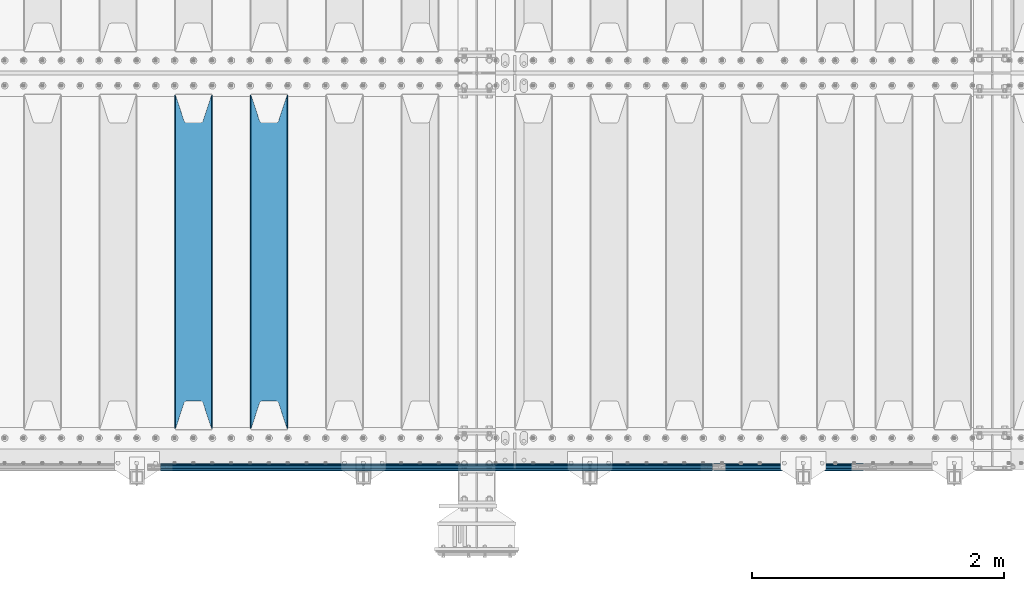
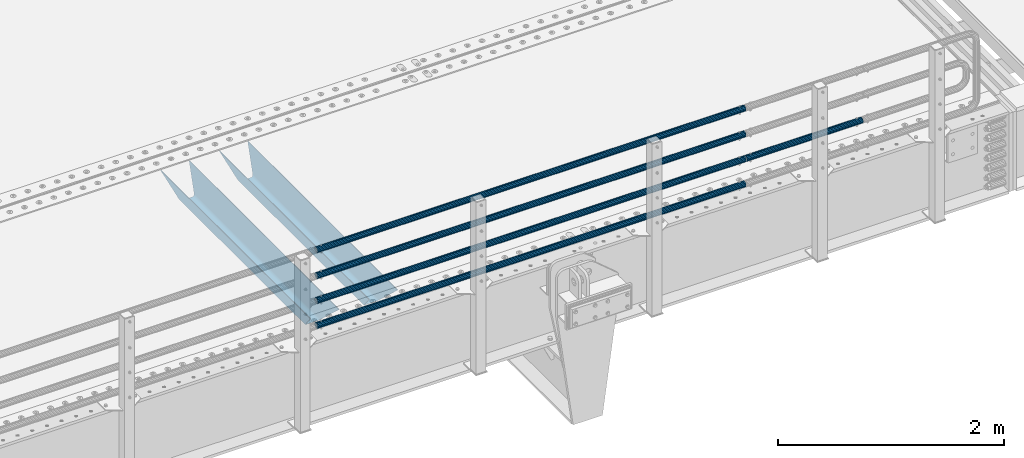
# One storey, part 108 of 257: 7 beams.
"""IFC2X3 building model written with IfcOpenShell, lengths in millimetres."""

from ifc_helpers import new_model, si_unit, frame, origin_with_axes, place, context, subcontext, project, spatial, faceted_brep, material, type_object, element, save


model = new_model("IFC2X3")

# Units and contexts
model_context = context("Model", 3, precision=1e-05, world=origin_with_axes())
body_context = subcontext(model_context, "Body", "Model", "MODEL_VIEW")
ifc_project = project(units=[si_unit("LENGTHUNIT", "METRE", prefix="MILLI"), si_unit("AREAUNIT", "SQUARE_METRE"), si_unit("VOLUMEUNIT", "CUBIC_METRE"), si_unit("MASSUNIT", "GRAM", prefix="KILO"), si_unit("TIMEUNIT", "SECOND"), si_unit("PLANEANGLEUNIT", "RADIAN"), si_unit("SOLIDANGLEUNIT", "STERADIAN"), si_unit("THERMODYNAMICTEMPERATUREUNIT", "DEGREE_CELSIUS"), si_unit("LUMINOUSINTENSITYUNIT", "LUMEN")], contexts=[model_context])

# Site, building, storey
site_placement = place(None, origin_with_axes())
site = spatial("IfcSite", under=ifc_project, at=site_placement, CompositionType="ELEMENT")
building_placement = place(site_placement, origin_with_axes())
building = spatial("IfcBuilding", under=site, at=building_placement, Name="Standard", CompositionType="ELEMENT")
storey_placement = place(building_placement, origin_with_axes())
storey = spatial("IfcBuildingStorey", under=building, at=storey_placement, Name="Undefined", CompositionType="ELEMENT", Elevation=0.0)

# Beams
ifc_material_1 = material(Name="STEEL/S355N")
beam_type_1 = type_object("IfcBeamType", PredefinedType="NOTDEFINED")
beam_1_placement = place(storey_placement, frame((53050.0, 175.0, -115.0), z_axis=(0.0, 0.0, 1.0), x_axis=(0.0, 1.0, 0.0)))
element("IfcBeam", 1, at=beam_1_placement, inside=storey, type_object=beam_type_1, material=ifc_material_1, context=body_context, shape_type="Brep", body=[
    faceted_brep([(0.0, 150.0, 115.0), (0.0, 143.690000000002, 115.0), (2650.00000000297, 143.690000000002, 115.0), (2650.00000000297, 150.0, 115.0), (2650.00000000297, 142.059565218406, 110.0000000031), (2650.00000000297, 148.369565218403, 110.0000000031), (2441.90079219208, -80.1103600731149, -98.0992078077845), (2437.7588105432, -77.5672621345584, -102.241189456673), (2434.06523489746, -74.4080125315522, -105.934765102404), (2430.91086095089, -70.7102721255724, -109.089139048974), (2428.37322971128, -66.5649389910031, -111.626770288588), (2426.51472138055, -62.0739139532889, -113.485278619323), (2425.38102192091, -57.3475956567636, -114.618978078955), (2424.99999999987, -52.5021667386536, -115.0), (2424.99999999987, 52.5021667386536, -115.0), (2425.38102192091, 57.3475956567636, -114.618978078955), (2426.51472138055, 62.0739139532889, -113.485278619323), (2428.37322971128, 66.5649389910031, -111.626770288588), (2430.91086095089, 70.7102721255724, -109.089139048974), (2434.06523489746, 74.4080125315522, -105.934765102404), (2437.7588105432, 77.5672621345584, -102.241189456673), (2441.90079219208, 80.1103600731149, -98.0992078077846), (2446.38936140511, 81.9747917625791, -93.6106385947584), (2448.24948500409, 76.2713538057287, -91.7505149957729), (2444.62967112262, 74.76777986261, -95.3703288772456), (2441.28936334126, 72.7168944282894, -98.710636658607), (2438.31067330438, 70.1691124903809, -101.689326695487), (2435.76682334747, 67.1870637758839, -104.233176652398), (2433.72034654133, 63.8440531834931, -106.279653458539), (2432.22154950041, 60.2222587982324, -107.778450499454), (2431.30727574265, 56.4107117849126, -108.692724257221), (2430.99999999987, 52.5031078186876, -109.0), (2430.99999999987, -52.5031078186876, -109.0), (2431.30727574265, -56.4107117849126, -108.692724257221), (2432.22154950041, -60.2222587982324, -107.778450499454), (2433.72034654133, -63.8440531834931, -106.279653458539), (2435.76682334747, -67.1870637758839, -104.233176652398), (2438.31067330438, -70.1691124903809, -101.689326695487), (2441.28936334126, -72.7168944282894, -98.7106366586071), (2444.62967112262, -74.76777986261, -95.3703288772457), (2448.24948500409, -76.2713538057287, -91.7505149957729), (2650.00000000297, -142.059565218406, 110.0000000031), (2650.00000000297, -148.369565218403, 110.0000000031), (2446.38936140511, -81.9747917625791, -93.6106385947584), (2650.00000000297, -143.690000000002, 115.0), (2650.00000000297, -150.0, 115.0), (0.0, -143.690000000002, 115.0), (0.0, -150.0, 115.0), (0.0, -148.369565218258, 110.000000002662), (203.61063859742, -81.9747917625791, -93.6106385947584), (208.099207810447, -80.1103600731149, -98.0992078077845), (212.241189459335, -77.5672621345584, -102.241189456673), (215.934765105066, -74.4080125315522, -105.934765102404), (219.089139051636, -70.7102721255724, -109.089139048974), (221.626770291251, -66.5649389910031, -111.626770288588), (223.485278621985, -62.0739139532889, -113.485278619323), (224.618978081617, -57.3475956567636, -114.618978078955), (225.000000002662, -52.5021667386536, -115.0), (225.000000002662, 52.5021667386536, -115.0), (224.618978081617, 57.3475956567636, -114.618978078955), (223.485278621985, 62.0739139532889, -113.485278619323), (221.626770291251, 66.5649389910031, -111.626770288588), (219.089139051636, 70.7102721255724, -109.089139048974), (215.934765105066, 74.4080125315522, -105.934765102404), (212.241189459335, 77.5672621345584, -102.241189456673), (208.099207810447, 80.1103600731149, -98.0992078077846), (203.61063859742, 81.9747917625791, -93.6106385947584), (0.0, 148.369565218258, 110.000000002662), (0.0, 142.05956521826, 110.000000002662), (201.750514998435, 76.2713538057287, -91.7505149957729), (205.370328879908, 74.76777986261, -95.3703288772456), (208.710636661269, 72.7168944282894, -98.710636658607), (211.689326698149, 70.1691124903809, -101.689326695487), (214.233176655061, 67.1870637758839, -104.233176652398), (216.279653461201, 63.8440531834931, -106.279653458539), (217.778450502116, 60.2222587982324, -107.778450499454), (218.692724259884, 56.4107117849126, -108.692724257221), (219.000000002662, 52.5031078186876, -109.0), (219.000000002662, -52.5031078186876, -109.0), (218.692724259884, -56.4107117849126, -108.692724257221), (217.778450502116, -60.2222587982324, -107.778450499454), (216.279653461201, -63.8440531834931, -106.279653458539), (214.233176655061, -67.1870637758839, -104.233176652398), (211.689326698149, -70.1691124903809, -101.689326695487), (208.710636661269, -72.7168944282894, -98.7106366586071), (205.370328879908, -74.76777986261, -95.3703288772457), (201.750514998435, -76.2713538057287, -91.7505149957729), (0.0, -142.05956521826, 110.000000002662)], [[[0, 1, 2, 3]], [[3, 2, 4, 5]], [[6, 7, 8, 9, 10, 11, 12, 13, 14, 15, 16, 17, 18, 19, 20, 21, 22, 5, 4, 23, 24, 25, 26, 27, 28, 29, 30, 31, 32, 33, 34, 35, 36, 37, 38, 39, 40, 41, 42, 43]], [[44, 45, 42, 41]], [[46, 47, 45, 44]], [[43, 42, 45, 47, 48, 49]], [[6, 43, 49, 50]], [[7, 6, 50, 51]], [[8, 7, 51, 52]], [[9, 8, 52, 53]], [[10, 9, 53, 54]], [[11, 10, 54, 55]], [[12, 11, 55, 56]], [[13, 12, 56, 57]], [[14, 13, 57, 58]], [[15, 14, 58, 59]], [[16, 15, 59, 60]], [[17, 16, 60, 61]], [[18, 17, 61, 62]], [[19, 18, 62, 63]], [[20, 19, 63, 64]], [[21, 20, 64, 65]], [[22, 21, 65, 66]], [[0, 3, 5, 22, 66, 67]], [[1, 0, 67, 68]], [[23, 4, 2, 1, 68, 69]], [[24, 23, 69, 70]], [[25, 24, 70, 71]], [[26, 25, 71, 72]], [[27, 26, 72, 73]], [[28, 27, 73, 74]], [[29, 28, 74, 75]], [[30, 29, 75, 76]], [[31, 30, 76, 77]], [[32, 31, 77, 78]], [[33, 32, 78, 79]], [[34, 33, 79, 80]], [[35, 34, 80, 81]], [[36, 35, 81, 82]], [[37, 36, 82, 83]], [[38, 37, 83, 84]], [[39, 38, 84, 85]], [[40, 39, 85, 86]], [[46, 44, 41, 40, 86, 87]], [[47, 46, 87, 48]], [[86, 85, 84, 83, 82, 81, 80, 79, 78, 77, 76, 75, 74, 73, 72, 71, 70, 69, 68, 67, 66, 65, 64, 63, 62, 61, 60, 59, 58, 57, 56, 55, 54, 53, 52, 51, 50, 49, 48, 87]]]),
])
beam_2_placement = place(storey_placement, frame((52450.0, 175.0, -115.0), z_axis=(0.0, 0.0, 1.0), x_axis=(0.0, 1.0, 0.0)))
element("IfcBeam", 2, at=beam_2_placement, inside=storey, type_object=beam_type_1, material=ifc_material_1, context=body_context, shape_type="Brep", body=[
    faceted_brep([(0.0, 150.0, 115.0), (0.0, 143.690000000002, 115.0), (2650.00000000297, 143.690000000002, 115.0), (2650.00000000297, 150.0, 115.0), (2650.00000000297, 142.059565218406, 110.0000000031), (2650.00000000297, 148.369565218403, 110.0000000031), (2441.90079219208, -80.1103600731149, -98.0992078077845), (2437.7588105432, -77.5672621345584, -102.241189456673), (2434.06523489746, -74.4080125315522, -105.934765102404), (2430.91086095089, -70.7102721255724, -109.089139048974), (2428.37322971128, -66.5649389910031, -111.626770288588), (2426.51472138055, -62.0739139532889, -113.485278619323), (2425.38102192091, -57.3475956567636, -114.618978078955), (2424.99999999987, -52.5021667386536, -115.0), (2424.99999999987, 52.5021667386536, -115.0), (2425.38102192091, 57.3475956567636, -114.618978078955), (2426.51472138055, 62.0739139532889, -113.485278619323), (2428.37322971128, 66.5649389910031, -111.626770288588), (2430.91086095089, 70.7102721255724, -109.089139048974), (2434.06523489746, 74.4080125315522, -105.934765102404), (2437.7588105432, 77.5672621345584, -102.241189456673), (2441.90079219208, 80.1103600731149, -98.0992078077846), (2446.38936140511, 81.9747917625791, -93.6106385947584), (2448.24948500409, 76.2713538057287, -91.7505149957729), (2444.62967112262, 74.76777986261, -95.3703288772456), (2441.28936334126, 72.7168944282894, -98.710636658607), (2438.31067330438, 70.1691124903809, -101.689326695487), (2435.76682334747, 67.1870637758839, -104.233176652398), (2433.72034654133, 63.8440531834931, -106.279653458539), (2432.22154950041, 60.2222587982324, -107.778450499454), (2431.30727574265, 56.4107117849126, -108.692724257221), (2430.99999999987, 52.5031078186876, -109.0), (2430.99999999987, -52.5031078186876, -109.0), (2431.30727574265, -56.4107117849126, -108.692724257221), (2432.22154950041, -60.2222587982324, -107.778450499454), (2433.72034654133, -63.8440531834931, -106.279653458539), (2435.76682334747, -67.1870637758839, -104.233176652398), (2438.31067330438, -70.1691124903809, -101.689326695487), (2441.28936334126, -72.7168944282894, -98.7106366586071), (2444.62967112262, -74.76777986261, -95.3703288772457), (2448.24948500409, -76.2713538057287, -91.7505149957729), (2650.00000000297, -142.059565218406, 110.0000000031), (2650.00000000297, -148.369565218403, 110.0000000031), (2446.38936140511, -81.9747917625791, -93.6106385947584), (2650.00000000297, -143.690000000002, 115.0), (2650.00000000297, -150.0, 115.0), (0.0, -143.690000000002, 115.0), (0.0, -150.0, 115.0), (0.0, -148.369565218258, 110.000000002662), (203.61063859742, -81.9747917625791, -93.6106385947584), (208.099207810447, -80.1103600731149, -98.0992078077845), (212.241189459335, -77.5672621345584, -102.241189456673), (215.934765105066, -74.4080125315522, -105.934765102404), (219.089139051636, -70.7102721255724, -109.089139048974), (221.626770291251, -66.5649389910031, -111.626770288588), (223.485278621985, -62.0739139532889, -113.485278619323), (224.618978081617, -57.3475956567636, -114.618978078955), (225.000000002662, -52.5021667386536, -115.0), (225.000000002662, 52.5021667386536, -115.0), (224.618978081617, 57.3475956567636, -114.618978078955), (223.485278621985, 62.0739139532889, -113.485278619323), (221.626770291251, 66.5649389910031, -111.626770288588), (219.089139051636, 70.7102721255724, -109.089139048974), (215.934765105066, 74.4080125315522, -105.934765102404), (212.241189459335, 77.5672621345584, -102.241189456673), (208.099207810447, 80.1103600731149, -98.0992078077846), (203.61063859742, 81.9747917625791, -93.6106385947584), (0.0, 148.369565218258, 110.000000002662), (0.0, 142.05956521826, 110.000000002662), (201.750514998435, 76.2713538057287, -91.7505149957729), (205.370328879908, 74.76777986261, -95.3703288772456), (208.710636661269, 72.7168944282894, -98.710636658607), (211.689326698149, 70.1691124903809, -101.689326695487), (214.233176655061, 67.1870637758839, -104.233176652398), (216.279653461201, 63.8440531834931, -106.279653458539), (217.778450502116, 60.2222587982324, -107.778450499454), (218.692724259884, 56.4107117849126, -108.692724257221), (219.000000002662, 52.5031078186876, -109.0), (219.000000002662, -52.5031078186876, -109.0), (218.692724259884, -56.4107117849126, -108.692724257221), (217.778450502116, -60.2222587982324, -107.778450499454), (216.279653461201, -63.8440531834931, -106.279653458539), (214.233176655061, -67.1870637758839, -104.233176652398), (211.689326698149, -70.1691124903809, -101.689326695487), (208.710636661269, -72.7168944282894, -98.7106366586071), (205.370328879908, -74.76777986261, -95.3703288772457), (201.750514998435, -76.2713538057287, -91.7505149957729), (0.0, -142.05956521826, 110.000000002662)], [[[0, 1, 2, 3]], [[3, 2, 4, 5]], [[6, 7, 8, 9, 10, 11, 12, 13, 14, 15, 16, 17, 18, 19, 20, 21, 22, 5, 4, 23, 24, 25, 26, 27, 28, 29, 30, 31, 32, 33, 34, 35, 36, 37, 38, 39, 40, 41, 42, 43]], [[44, 45, 42, 41]], [[46, 47, 45, 44]], [[43, 42, 45, 47, 48, 49]], [[6, 43, 49, 50]], [[7, 6, 50, 51]], [[8, 7, 51, 52]], [[9, 8, 52, 53]], [[10, 9, 53, 54]], [[11, 10, 54, 55]], [[12, 11, 55, 56]], [[13, 12, 56, 57]], [[14, 13, 57, 58]], [[15, 14, 58, 59]], [[16, 15, 59, 60]], [[17, 16, 60, 61]], [[18, 17, 61, 62]], [[19, 18, 62, 63]], [[20, 19, 63, 64]], [[21, 20, 64, 65]], [[22, 21, 65, 66]], [[0, 3, 5, 22, 66, 67]], [[1, 0, 67, 68]], [[23, 4, 2, 1, 68, 69]], [[24, 23, 69, 70]], [[25, 24, 70, 71]], [[26, 25, 71, 72]], [[27, 26, 72, 73]], [[28, 27, 73, 74]], [[29, 28, 74, 75]], [[30, 29, 75, 76]], [[31, 30, 76, 77]], [[32, 31, 77, 78]], [[33, 32, 78, 79]], [[34, 33, 79, 80]], [[35, 34, 80, 81]], [[36, 35, 81, 82]], [[37, 36, 82, 83]], [[38, 37, 83, 84]], [[39, 38, 84, 85]], [[40, 39, 85, 86]], [[46, 44, 41, 40, 86, 87]], [[47, 46, 87, 48]], [[86, 85, 84, 83, 82, 81, 80, 79, 78, 77, 76, 75, 74, 73, 72, 71, 70, 69, 68, 67, 66, 65, 64, 63, 62, 61, 60, 59, 58, 57, 56, 55, 54, 53, 52, 51, 50, 49, 48, 87]]]),
])
ifc_material_2 = material()
beam_type_2 = type_object("IfcBeamType", PredefinedType="NOTDEFINED")
beam_3_placement = place(storey_placement, frame((56571.9999999999, -129.849999999805, 149.849999999725), z_axis=(0.0, 0.0, -1.0), x_axis=(-1.0, 0.0, 0.0)))
element("IfcBeam", 3, at=beam_3_placement, inside=storey, type_object=beam_type_2, material=ifc_material_2, context=body_context, shape_type="Brep", body=[
    faceted_brep([(0.0, -26.5499999999993, 0.0), (0.0, -24.5290015881747, 10.1602451292931), (4384.0, -24.5290015881747, 10.1602451292931), (4384.0, -26.5499999999993, 0.0), (0.0, -18.7736850405036, 18.7736850405028), (4384.0, -18.7736850405036, 18.7736850405028), (0.0, -10.1602451292929, 24.5290015881747), (4384.0, -10.1602451292929, 24.5290015881747), (0.0, 0.0, 26.55), (4384.0, 0.0, 26.55), (0.0, 10.1602451292929, 24.5290015881747), (4384.0, 10.1602451292929, 24.5290015881747), (0.0, 18.7736850405036, 18.7736850405028), (4384.0, 18.7736850405036, 18.7736850405028), (0.0, 24.5290015881747, 10.1602451292931), (4384.0, 24.5290015881747, 10.1602451292931), (0.0, 26.5499999999993, 0.0), (4384.0, 26.5499999999993, 0.0), (0.0, 24.5290015881747, -10.1602451292931), (4384.0, 24.5290015881747, -10.1602451292931), (0.0, 18.7736850405036, -18.7736850405028), (4384.0, 18.7736850405036, -18.7736850405028), (0.0, 10.1602451292929, -24.5290015881747), (4384.0, 10.1602451292929, -24.5290015881747), (0.0, 0.0, -26.55), (4384.0, 0.0, -26.55), (0.0, -10.1602451292929, -24.5290015881747), (4384.0, -10.1602451292929, -24.5290015881747), (0.0, -18.7736850405036, -18.7736850405028), (4384.0, -18.7736850405036, -18.7736850405028), (0.0, -24.5290015881747, -10.1602451292931), (4384.0, -24.5290015881747, -10.1602451292931), (0.0, -30.1499999999996, 0.0), (0.0, -27.8549679052157, -11.5379054858058), (4384.0, -27.8549679052157, -11.5379054858075), (4384.0, -30.1499999999996, 0.0), (0.0, -21.3192694527752, -21.3192694527752), (4384.0, -21.3192694527752, -21.3192694527744), (0.0, -11.5379054858076, -27.8549679052157), (4384.0, -11.5379054858076, -27.8549679052153), (0.0, 0.0, -30.1500000000015), (4384.0, 0.0, -30.15), (0.0, 11.5379054858076, -27.8549679052157), (4384.0, 11.5379054858076, -27.8549679052153), (0.0, 21.3192694527752, -21.3192694527752), (4384.0, 21.3192694527752, -21.3192694527744), (0.0, 27.8549679052157, -11.5379054858058), (4384.0, 27.8549679052157, -11.5379054858074), (0.0, 30.1499999999996, 0.0), (4384.0, 30.1499999999996, 0.0), (0.0, 27.8549679052157, 11.5379054858058), (4384.0, 27.8549679052157, 11.5379054858075), (0.0, 21.3192694527752, 21.3192694527752), (4384.0, 21.3192694527752, 21.3192694527744), (0.0, 11.5379054858076, 27.8549679052157), (4384.0, 11.5379054858076, 27.8549679052153), (0.0, 0.0, 30.1500000000015), (4384.0, 0.0, 30.15), (0.0, -11.5379054858076, 27.8549679052157), (4384.0, -11.5379054858076, 27.8549679052153), (0.0, -21.3192694527752, 21.3192694527752), (4384.0, -21.3192694527752, 21.3192694527744), (0.0, -27.8549679052157, 11.5379054858058), (4384.0, -27.8549679052157, 11.5379054858075)], [[[0, 1, 2, 3]], [[1, 4, 5, 2]], [[4, 6, 7, 5]], [[6, 8, 9, 7]], [[8, 10, 11, 9]], [[10, 12, 13, 11]], [[12, 14, 15, 13]], [[14, 16, 17, 15]], [[16, 18, 19, 17]], [[18, 20, 21, 19]], [[20, 22, 23, 21]], [[22, 24, 25, 23]], [[24, 26, 27, 25]], [[26, 28, 29, 27]], [[28, 30, 31, 29]], [[30, 0, 3, 31]], [[32, 33, 34, 35]], [[33, 36, 37, 34]], [[36, 38, 39, 37]], [[38, 40, 41, 39]], [[40, 42, 43, 41]], [[42, 44, 45, 43]], [[44, 46, 47, 45]], [[46, 48, 49, 47]], [[48, 50, 51, 49]], [[50, 52, 53, 51]], [[52, 54, 55, 53]], [[54, 56, 57, 55]], [[56, 58, 59, 57]], [[58, 60, 61, 59]], [[60, 62, 63, 61]], [[62, 32, 35, 63]], [[37, 39, 41, 43, 45, 47, 49, 51, 53, 55, 57, 59, 61, 63, 35, 34], [5, 7, 9, 11, 13, 15, 17, 19, 21, 23, 25, 27, 29, 31, 3, 2]], [[62, 60, 58, 56, 54, 52, 50, 48, 46, 44, 42, 40, 38, 36, 33, 32], [30, 28, 26, 24, 22, 20, 18, 16, 14, 12, 10, 8, 6, 4, 1, 0]]]),
])
beam_4_placement = place(storey_placement, frame((56571.9999999999, -129.849999999805, 420.149999999728), z_axis=(0.0, 0.0, -1.0), x_axis=(-1.0, 0.0, 0.0)))
element("IfcBeam", 4, at=beam_4_placement, inside=storey, type_object=beam_type_2, material=ifc_material_2, context=body_context, shape_type="Brep", body=[
    faceted_brep([(0.0, -26.5499999999993, 0.0), (0.0, -24.5290015881747, 10.1602451292931), (4384.0, -24.5290015881747, 10.1602451292931), (4384.0, -26.5499999999993, 0.0), (0.0, -18.7736850405036, 18.7736850405028), (4384.0, -18.7736850405036, 18.7736850405028), (0.0, -10.1602451292929, 24.5290015881747), (4384.0, -10.1602451292929, 24.5290015881747), (0.0, 0.0, 26.55), (4384.0, 0.0, 26.55), (0.0, 10.1602451292929, 24.5290015881747), (4384.0, 10.1602451292929, 24.5290015881747), (0.0, 18.7736850405036, 18.7736850405028), (4384.0, 18.7736850405036, 18.7736850405028), (0.0, 24.5290015881747, 10.1602451292931), (4384.0, 24.5290015881747, 10.1602451292931), (0.0, 26.5499999999993, 0.0), (4384.0, 26.5499999999993, 0.0), (0.0, 24.5290015881747, -10.1602451292931), (4384.0, 24.5290015881747, -10.1602451292931), (0.0, 18.7736850405036, -18.7736850405028), (4384.0, 18.7736850405036, -18.7736850405028), (0.0, 10.1602451292929, -24.5290015881747), (4384.0, 10.1602451292929, -24.5290015881747), (0.0, 0.0, -26.55), (4384.0, 0.0, -26.55), (0.0, -10.1602451292929, -24.5290015881747), (4384.0, -10.1602451292929, -24.5290015881747), (0.0, -18.7736850405036, -18.7736850405028), (4384.0, -18.7736850405036, -18.7736850405028), (0.0, -24.5290015881747, -10.1602451292931), (4384.0, -24.5290015881747, -10.1602451292931), (0.0, -30.1499999999996, 0.0), (0.0, -27.8549679052157, -11.5379054858058), (4384.0, -27.8549679052157, -11.5379054858075), (4384.0, -30.1499999999996, 0.0), (0.0, -21.3192694527752, -21.3192694527752), (4384.0, -21.3192694527752, -21.3192694527744), (0.0, -11.5379054858076, -27.8549679052157), (4384.0, -11.5379054858076, -27.8549679052153), (0.0, 0.0, -30.1500000000015), (4384.0, 0.0, -30.15), (0.0, 11.5379054858076, -27.8549679052157), (4384.0, 11.5379054858076, -27.8549679052153), (0.0, 21.3192694527752, -21.3192694527752), (4384.0, 21.3192694527752, -21.3192694527744), (0.0, 27.8549679052157, -11.5379054858058), (4384.0, 27.8549679052157, -11.5379054858074), (0.0, 30.1499999999996, 0.0), (4384.0, 30.1499999999996, 0.0), (0.0, 27.8549679052157, 11.5379054858058), (4384.0, 27.8549679052157, 11.5379054858075), (0.0, 21.3192694527752, 21.3192694527752), (4384.0, 21.3192694527752, 21.3192694527744), (0.0, 11.5379054858076, 27.8549679052157), (4384.0, 11.5379054858076, 27.8549679052153), (0.0, 0.0, 30.1500000000015), (4384.0, 0.0, 30.15), (0.0, -11.5379054858076, 27.8549679052157), (4384.0, -11.5379054858076, 27.8549679052153), (0.0, -21.3192694527752, 21.3192694527752), (4384.0, -21.3192694527752, 21.3192694527744), (0.0, -27.8549679052157, 11.5379054858058), (4384.0, -27.8549679052157, 11.5379054858075)], [[[0, 1, 2, 3]], [[1, 4, 5, 2]], [[4, 6, 7, 5]], [[6, 8, 9, 7]], [[8, 10, 11, 9]], [[10, 12, 13, 11]], [[12, 14, 15, 13]], [[14, 16, 17, 15]], [[16, 18, 19, 17]], [[18, 20, 21, 19]], [[20, 22, 23, 21]], [[22, 24, 25, 23]], [[24, 26, 27, 25]], [[26, 28, 29, 27]], [[28, 30, 31, 29]], [[30, 0, 3, 31]], [[32, 33, 34, 35]], [[33, 36, 37, 34]], [[36, 38, 39, 37]], [[38, 40, 41, 39]], [[40, 42, 43, 41]], [[42, 44, 45, 43]], [[44, 46, 47, 45]], [[46, 48, 49, 47]], [[48, 50, 51, 49]], [[50, 52, 53, 51]], [[52, 54, 55, 53]], [[54, 56, 57, 55]], [[56, 58, 59, 57]], [[58, 60, 61, 59]], [[60, 62, 63, 61]], [[62, 32, 35, 63]], [[37, 39, 41, 43, 45, 47, 49, 51, 53, 55, 57, 59, 61, 63, 35, 34], [5, 7, 9, 11, 13, 15, 17, 19, 21, 23, 25, 27, 29, 31, 3, 2]], [[62, 60, 58, 56, 54, 52, 50, 48, 46, 44, 42, 40, 38, 36, 33, 32], [30, 28, 26, 24, 22, 20, 18, 16, 14, 12, 10, 8, 6, 4, 1, 0]]]),
])
beam_5_placement = place(storey_placement, frame((56571.9999999999, -129.849999999805, 969.849999999725), z_axis=(0.0, 0.0, -1.0), x_axis=(-1.0, 0.0, 0.0)))
element("IfcBeam", 5, at=beam_5_placement, inside=storey, type_object=beam_type_2, material=ifc_material_2, context=body_context, shape_type="Brep", body=[
    faceted_brep([(0.0, -26.5499999999993, 0.0), (0.0, -24.5290015881747, 10.1602451292931), (4384.0, -24.5290015881747, 10.1602451292931), (4384.0, -26.5499999999993, 0.0), (0.0, -18.7736850405036, 18.7736850405028), (4384.0, -18.7736850405036, 18.7736850405028), (0.0, -10.1602451292929, 24.5290015881747), (4384.0, -10.1602451292929, 24.5290015881747), (0.0, 0.0, 26.55), (4384.0, 0.0, 26.55), (0.0, 10.1602451292929, 24.5290015881747), (4384.0, 10.1602451292929, 24.5290015881747), (0.0, 18.7736850405036, 18.7736850405028), (4384.0, 18.7736850405036, 18.7736850405028), (0.0, 24.5290015881747, 10.1602451292931), (4384.0, 24.5290015881747, 10.1602451292931), (0.0, 26.5499999999993, 0.0), (4384.0, 26.5499999999993, 0.0), (0.0, 24.5290015881747, -10.1602451292931), (4384.0, 24.5290015881747, -10.1602451292931), (0.0, 18.7736850405036, -18.7736850405028), (4384.0, 18.7736850405036, -18.7736850405028), (0.0, 10.1602451292929, -24.5290015881747), (4384.0, 10.1602451292929, -24.5290015881747), (0.0, 0.0, -26.55), (4384.0, 0.0, -26.55), (0.0, -10.1602451292929, -24.5290015881747), (4384.0, -10.1602451292929, -24.5290015881747), (0.0, -18.7736850405036, -18.7736850405028), (4384.0, -18.7736850405036, -18.7736850405028), (0.0, -24.5290015881747, -10.1602451292931), (4384.0, -24.5290015881747, -10.1602451292931), (0.0, -30.1499999999996, 0.0), (0.0, -27.8549679052157, -11.5379054858058), (4384.0, -27.8549679052157, -11.5379054858075), (4384.0, -30.1499999999996, 0.0), (0.0, -21.3192694527752, -21.3192694527752), (4384.0, -21.3192694527752, -21.3192694527744), (0.0, -11.5379054858076, -27.8549679052157), (4384.0, -11.5379054858076, -27.8549679052153), (0.0, 0.0, -30.1500000000015), (4384.0, 0.0, -30.15), (0.0, 11.5379054858076, -27.8549679052157), (4384.0, 11.5379054858076, -27.8549679052153), (0.0, 21.3192694527752, -21.3192694527752), (4384.0, 21.3192694527752, -21.3192694527744), (0.0, 27.8549679052157, -11.5379054858058), (4384.0, 27.8549679052157, -11.5379054858074), (0.0, 30.1499999999996, 0.0), (4384.0, 30.1499999999996, 0.0), (0.0, 27.8549679052157, 11.5379054858058), (4384.0, 27.8549679052157, 11.5379054858075), (0.0, 21.3192694527752, 21.3192694527752), (4384.0, 21.3192694527752, 21.3192694527744), (0.0, 11.5379054858076, 27.8549679052157), (4384.0, 11.5379054858076, 27.8549679052153), (0.0, 0.0, 30.1500000000015), (4384.0, 0.0, 30.15), (0.0, -11.5379054858076, 27.8549679052157), (4384.0, -11.5379054858076, 27.8549679052153), (0.0, -21.3192694527752, 21.3192694527752), (4384.0, -21.3192694527752, 21.3192694527744), (0.0, -27.8549679052157, 11.5379054858058), (4384.0, -27.8549679052157, 11.5379054858075)], [[[0, 1, 2, 3]], [[1, 4, 5, 2]], [[4, 6, 7, 5]], [[6, 8, 9, 7]], [[8, 10, 11, 9]], [[10, 12, 13, 11]], [[12, 14, 15, 13]], [[14, 16, 17, 15]], [[16, 18, 19, 17]], [[18, 20, 21, 19]], [[20, 22, 23, 21]], [[22, 24, 25, 23]], [[24, 26, 27, 25]], [[26, 28, 29, 27]], [[28, 30, 31, 29]], [[30, 0, 3, 31]], [[32, 33, 34, 35]], [[33, 36, 37, 34]], [[36, 38, 39, 37]], [[38, 40, 41, 39]], [[40, 42, 43, 41]], [[42, 44, 45, 43]], [[44, 46, 47, 45]], [[46, 48, 49, 47]], [[48, 50, 51, 49]], [[50, 52, 53, 51]], [[52, 54, 55, 53]], [[54, 56, 57, 55]], [[56, 58, 59, 57]], [[58, 60, 61, 59]], [[60, 62, 63, 61]], [[62, 32, 35, 63]], [[37, 39, 41, 43, 45, 47, 49, 51, 53, 55, 57, 59, 61, 63, 35, 34], [5, 7, 9, 11, 13, 15, 17, 19, 21, 23, 25, 27, 29, 31, 3, 2]], [[62, 60, 58, 56, 54, 52, 50, 48, 46, 44, 42, 40, 38, 36, 33, 32], [30, 28, 26, 24, 22, 20, 18, 16, 14, 12, 10, 8, 6, 4, 1, 0]]]),
])
beam_6_placement = place(storey_placement, frame((56582.0000000001, -129.850000000402, 419.849999999725), z_axis=(0.0, -1.0, 0.0), x_axis=(1.0, 0.0, 0.0)))
element("IfcBeam", 6, at=beam_6_placement, inside=storey, type_object=beam_type_2, material=ifc_material_2, context=body_context, shape_type="Brep", body=[
    faceted_brep([(0.0, -26.5499999999993, 0.0), (0.0, -24.5290015881747, 10.1602451292931), (1190.0, -24.5290015881747, 10.1602451292929), (1190.0, -26.55, 0.0), (0.0, -18.7736850405036, 18.7736850405028), (1190.0, -18.7736850405028, 18.7736850405036), (0.0, -10.1602451292929, 24.5290015881747), (1190.0, -10.1602451292931, 24.5290015881747), (0.0, 0.0, 26.55), (1190.0, 0.0, 26.5499999999993), (0.0, 10.1602451292929, 24.5290015881747), (1190.0, 10.1602451292932, 24.5290015881747), (0.0, 18.7736850405036, 18.7736850405028), (1190.0, 18.7736850405029, 18.7736850405036), (0.0, 24.5290015881747, 10.1602451292931), (1190.0, 24.5290015881747, 10.1602451292929), (0.0, 26.5499999999993, 0.0), (1190.0, 26.55, 0.0), (0.0, 24.5290015881747, -10.1602451292931), (1190.0, 24.5290015881747, -10.1602451292929), (0.0, 18.7736850405036, -18.7736850405028), (1190.0, 18.7736850405028, -18.7736850405036), (0.0, 10.1602451292929, -24.5290015881747), (1190.0, 10.1602451292931, -24.5290015881747), (0.0, 0.0, -26.55), (1190.0, 0.0, -26.5499999999993), (0.0, -10.1602451292929, -24.5290015881747), (1190.0, -10.1602451292931, -24.5290015881747), (0.0, -18.7736850405036, -18.7736850405028), (1190.0, -18.7736850405028, -18.7736850405036), (0.0, -24.5290015881747, -10.1602451292931), (1190.0, -24.5290015881747, -10.1602451292929), (0.0, -30.1499999999996, 0.0), (0.0, -27.8549679052157, -11.5379054858058), (1190.0, -27.8549679052153, -11.5379054858076), (1190.0, -30.15, 0.0), (0.0, -21.3192694527752, -21.3192694527752), (1190.0, -21.3192694527744, -21.3192694527752), (0.0, -11.5379054858076, -27.8549679052157), (1190.0, -11.5379054858075, -27.8549679052157), (0.0, 0.0, -30.1500000000015), (1190.0, 0.0, -30.1499999999996), (0.0, 11.5379054858076, -27.8549679052157), (1190.0, 11.5379054858075, -27.8549679052157), (0.0, 21.3192694527752, -21.3192694527752), (1190.0, 21.3192694527744, -21.3192694527752), (0.0, 27.8549679052157, -11.5379054858058), (1190.0, 27.8549679052153, -11.5379054858076), (0.0, 30.1499999999996, 0.0), (1190.0, 30.15, 0.0), (0.0, 27.8549679052157, 11.5379054858058), (1190.0, 27.8549679052153, 11.5379054858076), (0.0, 21.3192694527752, 21.3192694527752), (1190.0, 21.3192694527744, 21.3192694527752), (0.0, 11.5379054858076, 27.8549679052157), (1190.0, 11.5379054858075, 27.8549679052157), (0.0, 0.0, 30.1500000000015), (1190.0, 0.0, 30.1499999999996), (0.0, -11.5379054858076, 27.8549679052157), (1190.0, -11.5379054858075, 27.8549679052157), (0.0, -21.3192694527752, 21.3192694527752), (1190.0, -21.3192694527744, 21.3192694527752), (0.0, -27.8549679052157, 11.5379054858058), (1190.0, -27.8549679052153, 11.5379054858076)], [[[0, 1, 2, 3]], [[1, 4, 5, 2]], [[4, 6, 7, 5]], [[6, 8, 9, 7]], [[8, 10, 11, 9]], [[10, 12, 13, 11]], [[12, 14, 15, 13]], [[14, 16, 17, 15]], [[16, 18, 19, 17]], [[18, 20, 21, 19]], [[20, 22, 23, 21]], [[22, 24, 25, 23]], [[24, 26, 27, 25]], [[26, 28, 29, 27]], [[28, 30, 31, 29]], [[30, 0, 3, 31]], [[32, 33, 34, 35]], [[33, 36, 37, 34]], [[36, 38, 39, 37]], [[38, 40, 41, 39]], [[40, 42, 43, 41]], [[42, 44, 45, 43]], [[44, 46, 47, 45]], [[46, 48, 49, 47]], [[48, 50, 51, 49]], [[50, 52, 53, 51]], [[52, 54, 55, 53]], [[54, 56, 57, 55]], [[56, 58, 59, 57]], [[58, 60, 61, 59]], [[60, 62, 63, 61]], [[62, 32, 35, 63]], [[37, 39, 41, 43, 45, 47, 49, 51, 53, 55, 57, 59, 61, 63, 35, 34], [5, 7, 9, 11, 13, 15, 17, 19, 21, 23, 25, 27, 29, 31, 3, 2]], [[62, 60, 58, 56, 54, 52, 50, 48, 46, 44, 42, 40, 38, 36, 33, 32], [30, 28, 26, 24, 22, 20, 18, 16, 14, 12, 10, 8, 6, 4, 1, 0]]]),
])
beam_7_placement = place(storey_placement, frame((56571.9999999999, -129.849999999805, 689.849999999725), z_axis=(0.0, 0.0, -1.0), x_axis=(-1.0, 0.0, 0.0)))
element("IfcBeam", 7, at=beam_7_placement, inside=storey, type_object=beam_type_2, material=ifc_material_2, context=body_context, shape_type="Brep", body=[
    faceted_brep([(0.0, -26.5499999999993, 0.0), (0.0, -24.5290015881747, 10.1602451292931), (4384.0, -24.5290015881747, 10.1602451292931), (4384.0, -26.5499999999993, 0.0), (0.0, -18.7736850405036, 18.7736850405028), (4384.0, -18.7736850405036, 18.7736850405028), (0.0, -10.1602451292929, 24.5290015881747), (4384.0, -10.1602451292929, 24.5290015881747), (0.0, 0.0, 26.55), (4384.0, 0.0, 26.55), (0.0, 10.1602451292929, 24.5290015881747), (4384.0, 10.1602451292929, 24.5290015881747), (0.0, 18.7736850405036, 18.7736850405028), (4384.0, 18.7736850405036, 18.7736850405028), (0.0, 24.5290015881747, 10.1602451292931), (4384.0, 24.5290015881747, 10.1602451292931), (0.0, 26.5499999999993, 0.0), (4384.0, 26.5499999999993, 0.0), (0.0, 24.5290015881747, -10.1602451292931), (4384.0, 24.5290015881747, -10.1602451292931), (0.0, 18.7736850405036, -18.7736850405028), (4384.0, 18.7736850405036, -18.7736850405028), (0.0, 10.1602451292929, -24.5290015881747), (4384.0, 10.1602451292929, -24.5290015881747), (0.0, 0.0, -26.55), (4384.0, 0.0, -26.55), (0.0, -10.1602451292929, -24.5290015881747), (4384.0, -10.1602451292929, -24.5290015881747), (0.0, -18.7736850405036, -18.7736850405028), (4384.0, -18.7736850405036, -18.7736850405028), (0.0, -24.5290015881747, -10.1602451292931), (4384.0, -24.5290015881747, -10.1602451292931), (0.0, -30.1499999999996, 0.0), (0.0, -27.8549679052157, -11.5379054858058), (4384.0, -27.8549679052157, -11.5379054858075), (4384.0, -30.1499999999996, 0.0), (0.0, -21.3192694527752, -21.3192694527752), (4384.0, -21.3192694527752, -21.3192694527744), (0.0, -11.5379054858076, -27.8549679052157), (4384.0, -11.5379054858076, -27.8549679052153), (0.0, 0.0, -30.1500000000015), (4384.0, 0.0, -30.15), (0.0, 11.5379054858076, -27.8549679052157), (4384.0, 11.5379054858076, -27.8549679052153), (0.0, 21.3192694527752, -21.3192694527752), (4384.0, 21.3192694527752, -21.3192694527744), (0.0, 27.8549679052157, -11.5379054858058), (4384.0, 27.8549679052157, -11.5379054858074), (0.0, 30.1499999999996, 0.0), (4384.0, 30.1499999999996, 0.0), (0.0, 27.8549679052157, 11.5379054858058), (4384.0, 27.8549679052157, 11.5379054858075), (0.0, 21.3192694527752, 21.3192694527752), (4384.0, 21.3192694527752, 21.3192694527744), (0.0, 11.5379054858076, 27.8549679052157), (4384.0, 11.5379054858076, 27.8549679052153), (0.0, 0.0, 30.1500000000015), (4384.0, 0.0, 30.15), (0.0, -11.5379054858076, 27.8549679052157), (4384.0, -11.5379054858076, 27.8549679052153), (0.0, -21.3192694527752, 21.3192694527752), (4384.0, -21.3192694527752, 21.3192694527744), (0.0, -27.8549679052157, 11.5379054858058), (4384.0, -27.8549679052157, 11.5379054858075)], [[[0, 1, 2, 3]], [[1, 4, 5, 2]], [[4, 6, 7, 5]], [[6, 8, 9, 7]], [[8, 10, 11, 9]], [[10, 12, 13, 11]], [[12, 14, 15, 13]], [[14, 16, 17, 15]], [[16, 18, 19, 17]], [[18, 20, 21, 19]], [[20, 22, 23, 21]], [[22, 24, 25, 23]], [[24, 26, 27, 25]], [[26, 28, 29, 27]], [[28, 30, 31, 29]], [[30, 0, 3, 31]], [[32, 33, 34, 35]], [[33, 36, 37, 34]], [[36, 38, 39, 37]], [[38, 40, 41, 39]], [[40, 42, 43, 41]], [[42, 44, 45, 43]], [[44, 46, 47, 45]], [[46, 48, 49, 47]], [[48, 50, 51, 49]], [[50, 52, 53, 51]], [[52, 54, 55, 53]], [[54, 56, 57, 55]], [[56, 58, 59, 57]], [[58, 60, 61, 59]], [[60, 62, 63, 61]], [[62, 32, 35, 63]], [[37, 39, 41, 43, 45, 47, 49, 51, 53, 55, 57, 59, 61, 63, 35, 34], [5, 7, 9, 11, 13, 15, 17, 19, 21, 23, 25, 27, 29, 31, 3, 2]], [[62, 60, 58, 56, 54, 52, 50, 48, 46, 44, 42, 40, 38, 36, 33, 32], [30, 28, 26, 24, 22, 20, 18, 16, 14, 12, 10, 8, 6, 4, 1, 0]]]),
])

save(model, "model.ifc")
